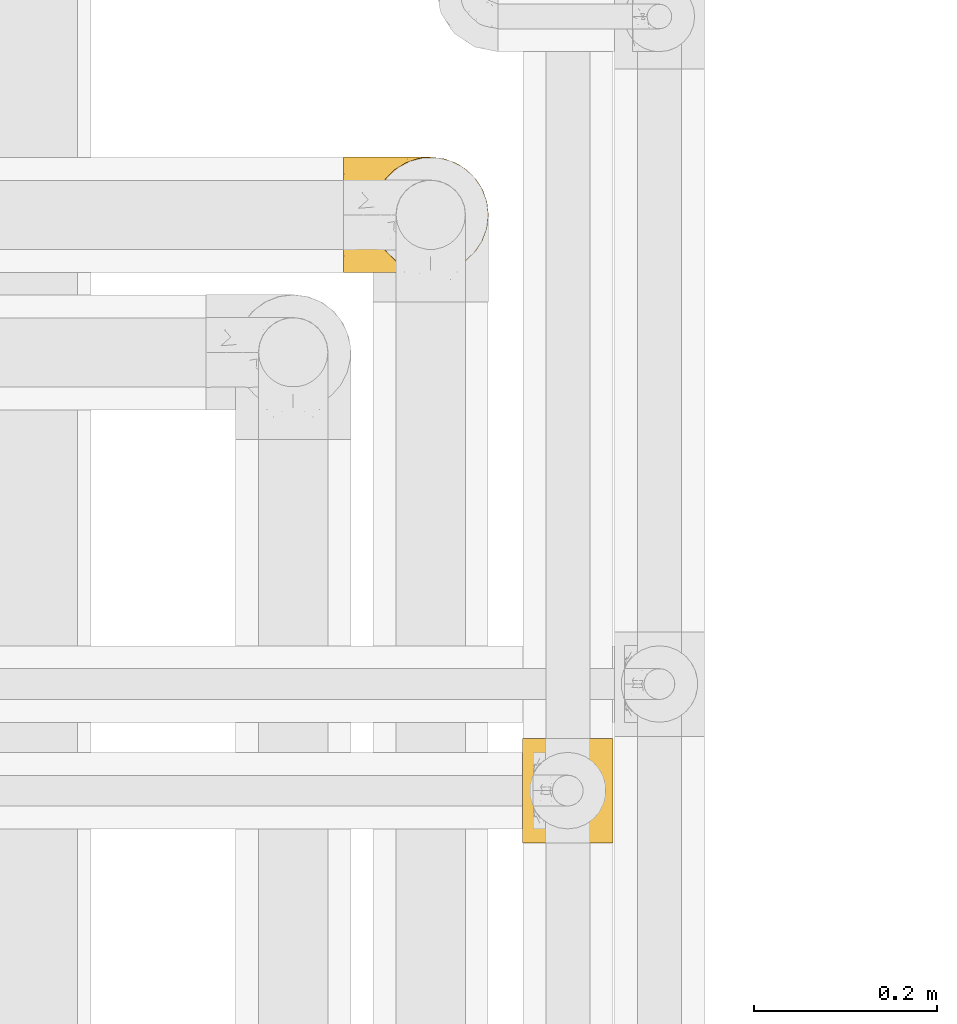
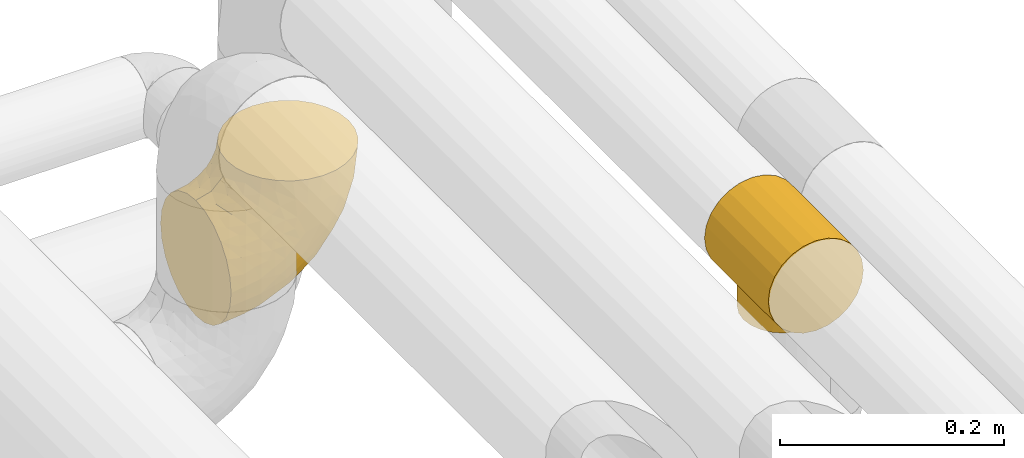
# One storey, part 491 of 827: 2 coverings.
"""IFC2X3 building model written with IfcOpenShell, lengths in millimetres."""

from ifc_helpers import new_model, entity, si_unit, converted_unit, derived_unit, direction, frame, origin, place, context, subcontext, project, spatial, faceted_brep, element, save


model = new_model("IFC2X3")

# Units and contexts
model_context = context("Model", 3, precision=0.01, world=origin(), true_north=direction((6.12303176911189e-17, 1.0)))
body_context = subcontext(model_context, "Body", "Model", "MODEL_VIEW")
ifc_project = project(units=[si_unit("LENGTHUNIT", "METRE", prefix="MILLI"), si_unit("AREAUNIT", "SQUARE_METRE"), si_unit("VOLUMEUNIT", "CUBIC_METRE"), converted_unit("PLANEANGLEUNIT", "DEGREE", entity("IfcRatioMeasure", 0.0174532925199433), si_unit("PLANEANGLEUNIT", "RADIAN"), dimensions=[0, 0, 0, 0, 0, 0, 0]), si_unit("MASSUNIT", "GRAM", prefix="KILO"), derived_unit("MASSDENSITYUNIT", [(si_unit("MASSUNIT", "GRAM", prefix="KILO"), 1), (si_unit("LENGTHUNIT", "METRE"), -3)]), derived_unit("MOMENTOFINERTIAUNIT", [(si_unit("LENGTHUNIT", "METRE"), 4)]), si_unit("TIMEUNIT", "SECOND"), si_unit("FREQUENCYUNIT", "HERTZ"), si_unit("THERMODYNAMICTEMPERATUREUNIT", "DEGREE_CELSIUS"), derived_unit("THERMALTRANSMITTANCEUNIT", [(si_unit("MASSUNIT", "GRAM", prefix="KILO"), 1), (si_unit("THERMODYNAMICTEMPERATUREUNIT", "KELVIN"), -1), (si_unit("TIMEUNIT", "SECOND"), -3)]), derived_unit("VOLUMETRICFLOWRATEUNIT", [(si_unit("LENGTHUNIT", "METRE"), 3), (si_unit("TIMEUNIT", "SECOND"), -1)]), derived_unit("MASSFLOWRATEUNIT", [(si_unit("MASSUNIT", "GRAM", prefix="KILO"), 1), (si_unit("TIMEUNIT", "SECOND"), -1)]), derived_unit("ROTATIONALFREQUENCYUNIT", [(si_unit("TIMEUNIT", "SECOND"), -1)]), si_unit("ELECTRICCURRENTUNIT", "AMPERE"), si_unit("ELECTRICVOLTAGEUNIT", "VOLT"), si_unit("POWERUNIT", "WATT"), si_unit("FORCEUNIT", "NEWTON", prefix="KILO"), si_unit("ILLUMINANCEUNIT", "LUX"), si_unit("LUMINOUSFLUXUNIT", "LUMEN"), si_unit("LUMINOUSINTENSITYUNIT", "CANDELA"), derived_unit("USERDEFINED", [(si_unit("MASSUNIT", "GRAM", prefix="KILO"), -1), (si_unit("LENGTHUNIT", "METRE"), -2), (si_unit("TIMEUNIT", "SECOND"), 3), (si_unit("LUMINOUSFLUXUNIT", "LUMEN"), 1)]), derived_unit("LINEARVELOCITYUNIT", [(si_unit("LENGTHUNIT", "METRE"), 1), (si_unit("TIMEUNIT", "SECOND"), -1)]), si_unit("PRESSUREUNIT", "PASCAL"), derived_unit("USERDEFINED", [(si_unit("LENGTHUNIT", "METRE"), -2), (si_unit("MASSUNIT", "GRAM", prefix="KILO"), 1), (si_unit("TIMEUNIT", "SECOND"), -2)]), derived_unit("LINEARFORCEUNIT", [(si_unit("MASSUNIT", "GRAM", prefix="KILO"), 1), (si_unit("LENGTHUNIT", "METRE"), 1), (si_unit("TIMEUNIT", "SECOND"), -2), (si_unit("LENGTHUNIT", "METRE"), -1)]), derived_unit("PLANARFORCEUNIT", [(si_unit("MASSUNIT", "GRAM", prefix="KILO"), 1), (si_unit("LENGTHUNIT", "METRE"), 1), (si_unit("TIMEUNIT", "SECOND"), -2), (si_unit("LENGTHUNIT", "METRE"), -2)])], contexts=[model_context])

# Site, building, storey
site_placement = place(None, origin())
site = spatial("IfcSite", under=ifc_project, at=site_placement, CompositionType="ELEMENT")
building_placement = place(site_placement, origin())
building = spatial("IfcBuilding", under=site, at=building_placement, CompositionType="ELEMENT")
storey_placement = place(building_placement, frame((0.0, 0.0, 28200.0)))
storey = spatial("IfcBuildingStorey", under=building, at=storey_placement, Name="08", CompositionType="ELEMENT", Elevation=28200.0)

# Coverings
covering_1_placement = place(storey_placement, frame((60806.51, 16007.73, 2635.39)))
element("IfcCovering", 1, at=covering_1_placement, inside=storey, Name=":ADSK_", ObjectType=":ADSK_", PredefinedType="INSULATION", context=body_context, shape_type="Brep", body=[
    faceted_brep([(110.62, 3.18, 159.65), (123.95, 7.84, 159.65), (135.9, 15.35, 159.65), (145.89, 25.33, 159.65), (153.4, 37.29, 159.65), (158.06, 50.61, 159.65), (159.65, 64.65, 159.65), (158.06, 78.67, 159.65), (153.4, 92.0, 159.65), (145.89, 103.95, 159.65), (135.91, 113.94, 159.65), (123.95, 121.45, 159.65), (110.63, 126.11, 159.65), (96.6, 127.7, 159.65), (82.57, 126.11, 159.65), (69.24, 121.45, 159.65), (57.29, 113.94, 159.65), (47.3, 103.96, 159.65), (39.79, 92.0, 159.65), (35.13, 78.68, 159.65), (33.55, 64.65, 159.65), (35.13, 50.62, 159.65), (39.79, 37.29, 159.65), (47.3, 25.34, 159.65), (57.28, 15.35, 159.65), (69.24, 7.84, 159.65), (82.56, 3.18, 159.65), (96.6, 1.6, 159.65), (1.6, 64.65, 127.7), (1.6, 80.96, 125.55), (1.6, 96.17, 119.25), (1.6, 109.23, 109.23), (1.6, 119.25, 96.17), (1.6, 125.55, 80.96), (1.6, 126.29, 75.35), (1.6, 127.7, 64.65), (1.6, 125.55, 48.33), (1.6, 119.25, 33.12), (1.6, 109.23, 20.06), (1.6, 96.17, 10.04), (1.6, 80.96, 3.74), (1.6, 64.65, 1.6), (1.6, 48.33, 3.74), (1.6, 33.12, 10.04), (1.6, 20.06, 20.06), (1.6, 10.04, 33.12), (1.6, 3.74, 48.33), (1.6, 1.6, 64.65), (1.6, 3.01, 75.35), (1.6, 3.74, 80.96), (1.6, 10.04, 96.17), (1.6, 20.06, 109.23), (1.6, 33.12, 119.25), (1.6, 48.33, 125.55), (30.13, 28.19, 16.01), (39.4, 42.57, 10.29), (62.65, 30.59, 24.76), (28.52, 53.36, 4.94), (42.5, 64.65, 6.98), (115.57, 15.9, 87.32), (98.94, 18.23, 62.3), (111.29, 32.42, 58.52), (95.5, 45.22, 36.35), (80.62, 64.65, 22.77), (113.35, 64.65, 47.89), (43.71, 9.73, 40.91), (70.76, 16.54, 42.82), (62.71, 6.44, 57.25), (33.16, 4.21, 51.19), (53.41, 2.65, 66.64), (130.65, 23.51, 98.56), (137.68, 35.48, 94.44), (146.84, 33.22, 123.53), (66.58, 42.18, 20.12), (57.7, 53.52, 12.95), (39.88, 17.3, 28.48), (154.26, 64.65, 118.74), (152.07, 45.71, 121.88), (125.54, 48.33, 65.08), (142.81, 50.95, 92.08), (103.99, 6.44, 98.53), (79.4, 3.41, 81.84), (88.81, 8.33, 72.43), (104.86, 2.62, 134.31), (117.38, 6.65, 129.11), (57.43, 1.6, 82.79), (44.19, 1.6, 76.04), (30.95, 1.6, 69.29), (139.96, 22.17, 129.58), (127.03, 14.22, 115.86), (87.17, 26.48, 42.36), (78.45, 1.6, 103.81), (73.2, 1.6, 98.55), (67.94, 1.6, 93.3), (94.63, 1.6, 147.25), (93.29, 1.6, 138.77), (91.95, 1.6, 130.29), (94.6, 2.65, 107.83), (85.2, 1.6, 117.05), (138.47, 64.65, 80.62), (13.99, 1.6, 66.61), (40.46, 16.24, 121.29), (32.36, 27.48, 128.09), (28.71, 20.83, 118.04), (15.53, 3.08, 79.47), (29.06, 6.64, 94.94), (40.03, 2.74, 86.01), (45.36, 3.84, 94.69), (26.46, 3.28, 83.06), (47.56, 5.99, 104.39), (36.28, 10.3, 107.01), (55.57, 15.78, 148.3), (45.02, 24.69, 143.82), (57.55, 11.25, 134.19), (11.56, 27.69, 116.87), (19.2, 19.31, 111.58), (10.07, 37.19, 122.36), (21.04, 33.01, 124.16), (15.52, 8.24, 94.28), (13.84, 49.89, 128.25), (32.67, 50.1, 146.72), (24.86, 48.9, 134.92), (34.31, 36.15, 138.87), (81.47, 2.54, 133.28), (71.26, 3.58, 121.77), (81.64, 3.12, 145.83), (29.26, 64.65, 143.67), (70.65, 6.01, 139.93), (31.93, 64.65, 153.63), (27.99, 37.71, 132.32), (41.71, 22.19, 132.59), (50.14, 13.01, 126.42), (17.57, 12.97, 102.97), (37.62, 38.95, 149.52), (60.48, 6.55, 120.88), (17.57, 64.65, 131.98), (56.96, 2.52, 96.12), (48.98, 9.45, 115.84), (57.29, 4.58, 108.2), (68.25, 2.83, 110.85), (10.07, 92.1, 122.36), (16.58, 101.63, 118.35), (13.84, 79.39, 128.25), (13.99, 127.7, 66.61), (32.67, 79.2, 146.72), (24.86, 80.4, 134.92), (67.81, 126.41, 110.73), (61.09, 122.74, 121.83), (71.26, 125.71, 121.77), (57.43, 127.7, 82.79), (44.19, 127.7, 76.04), (40.03, 126.55, 86.01), (57.55, 118.04, 134.19), (51.01, 117.36, 124.9), (42.79, 108.2, 132.35), (26.46, 126.01, 83.06), (29.06, 122.65, 94.94), (17.57, 116.32, 102.97), (19.2, 109.98, 111.58), (40.46, 113.06, 121.29), (28.84, 107.85, 118.82), (33.48, 102.33, 128.68), (15.52, 121.05, 94.28), (15.53, 126.21, 79.47), (36.28, 118.99, 107.01), (37.62, 90.34, 149.51), (21.04, 96.28, 124.16), (94.63, 127.7, 147.25), (93.29, 127.7, 138.77), (34.31, 93.14, 138.87), (45.03, 104.6, 143.82), (70.65, 123.28, 139.92), (81.47, 126.75, 133.28), (55.58, 113.51, 148.3), (91.95, 127.7, 130.29), (81.64, 126.17, 145.83), (27.86, 91.96, 131.94), (78.45, 127.7, 103.81), (85.2, 127.7, 117.05), (56.96, 126.77, 96.12), (45.36, 125.45, 94.69), (47.57, 123.3, 104.39), (48.27, 119.94, 114.83), (67.94, 127.7, 93.3), (57.3, 124.71, 108.2), (30.95, 127.7, 69.29), (62.65, 98.7, 24.76), (30.13, 101.1, 16.01), (39.88, 111.99, 28.48), (43.71, 119.56, 40.91), (39.4, 86.72, 10.29), (55.79, 75.78, 12.23), (28.41, 75.87, 4.91), (53.41, 126.64, 66.64), (104.86, 126.67, 134.31), (117.39, 122.63, 129.11), (103.99, 122.85, 98.53), (125.54, 80.96, 65.08), (111.29, 96.87, 58.52), (137.69, 93.81, 94.45), (94.6, 126.64, 107.83), (79.4, 125.88, 81.84), (33.16, 125.08, 51.19), (68.78, 86.22, 20.8), (130.66, 105.77, 98.56), (139.97, 107.12, 129.58), (148.6, 96.19, 131.93), (115.58, 113.39, 87.32), (127.03, 115.06, 115.86), (70.76, 112.75, 42.82), (95.5, 84.07, 36.35), (62.71, 122.85, 57.25), (88.81, 120.97, 72.43), (98.94, 111.06, 62.3), (89.09, 96.3, 38.39), (78.72, 75.94, 22.86), (142.21, 80.53, 92.06), (152.07, 83.57, 121.88)], [[[0, 1, 2, 3, 4, 5, 6, 7, 8, 9, 10, 11, 12, 13, 14, 15, 16, 17, 18, 19, 20, 21, 22, 23, 24, 25, 26, 27]], [[28, 29, 30, 31, 32, 33, 34, 35, 36, 37, 38, 39, 40, 41, 42, 43, 44, 45, 46, 47, 48, 49, 50, 51, 52, 53]], [[54, 55, 56]], [[57, 41, 58]], [[59, 60, 61]], [[62, 63, 64]], [[65, 66, 67]], [[68, 67, 69]], [[70, 71, 72]], [[55, 73, 56]], [[43, 42, 55]], [[55, 74, 73]], [[44, 75, 45]], [[44, 43, 54]], [[76, 5, 77]], [[71, 78, 79]], [[45, 75, 65]], [[46, 68, 47]], [[80, 81, 82]], [[0, 83, 84]], [[69, 85, 86, 87]], [[69, 81, 85]], [[84, 1, 0]], [[2, 88, 3]], [[4, 3, 72]], [[44, 54, 75]], [[5, 4, 77]], [[89, 2, 1]], [[72, 3, 88]], [[5, 76, 6]], [[70, 88, 89]], [[68, 65, 67]], [[88, 2, 89]], [[56, 90, 66]], [[64, 78, 62]], [[81, 91, 92, 93, 85]], [[83, 27, 94, 95, 96]], [[62, 61, 90]], [[97, 96, 98, 91]], [[80, 97, 81]], [[42, 57, 55]], [[62, 78, 61]], [[84, 89, 1]], [[78, 64, 99]], [[57, 74, 55]], [[76, 77, 79]], [[77, 72, 71]], [[82, 81, 67]], [[97, 83, 96]], [[80, 89, 84]], [[79, 78, 99]], [[71, 70, 61]], [[81, 97, 91]], [[83, 80, 84]], [[68, 87, 100, 47]], [[81, 69, 67]], [[68, 69, 87]], [[65, 46, 45]], [[65, 68, 46]], [[66, 65, 75]], [[56, 66, 75]], [[66, 60, 82]], [[71, 61, 78]], [[60, 66, 90]], [[83, 97, 80]], [[27, 83, 0]], [[59, 70, 89]], [[70, 59, 61]], [[89, 80, 59]], [[82, 59, 80]], [[55, 54, 43]], [[75, 54, 56]], [[66, 82, 67]], [[59, 82, 60]], [[41, 57, 42]], [[74, 57, 58]], [[58, 63, 74]], [[62, 74, 63]], [[74, 62, 73]], [[62, 56, 73]], [[4, 72, 77]], [[70, 72, 88]], [[76, 79, 99]], [[71, 79, 77]], [[62, 90, 56]], [[60, 90, 61]], [[101, 102, 103]], [[100, 87, 104]], [[105, 106, 107]], [[108, 104, 87]], [[107, 109, 110]], [[108, 87, 86]], [[111, 112, 113]], [[114, 51, 115]], [[116, 114, 117]], [[51, 50, 118]], [[119, 28, 53]], [[120, 121, 122]], [[98, 123, 124]], [[125, 96, 95]], [[116, 53, 52]], [[126, 121, 120]], [[104, 108, 118]], [[98, 124, 91]], [[25, 24, 127]], [[120, 128, 126]], [[122, 129, 102]], [[95, 94, 27, 26]], [[122, 102, 130]], [[125, 127, 123]], [[24, 111, 127]], [[21, 20, 128]], [[112, 130, 131]], [[48, 47, 100, 49]], [[132, 110, 115]], [[23, 111, 24]], [[129, 119, 117]], [[120, 133, 21]], [[112, 23, 22]], [[134, 113, 131]], [[121, 126, 135]], [[133, 112, 22]], [[128, 120, 21]], [[132, 51, 118]], [[120, 122, 133]], [[119, 121, 135]], [[129, 117, 102]], [[125, 26, 25]], [[26, 125, 95]], [[127, 125, 25]], [[28, 119, 135]], [[119, 53, 116]], [[127, 113, 124]], [[96, 125, 123]], [[112, 131, 113]], [[101, 103, 110]], [[85, 93, 136]], [[124, 123, 127]], [[98, 96, 123]], [[112, 111, 23]], [[127, 111, 113]], [[112, 133, 122]], [[21, 133, 22]], [[107, 110, 105]], [[110, 109, 137]], [[86, 106, 108]], [[138, 109, 136]], [[105, 118, 108]], [[107, 106, 85]], [[104, 50, 49]], [[124, 134, 139]], [[138, 93, 92]], [[92, 91, 139]], [[100, 104, 49]], [[118, 105, 132]], [[104, 118, 50]], [[110, 132, 105]], [[51, 132, 115]], [[108, 106, 105]], [[85, 106, 86]], [[114, 116, 52]], [[119, 116, 117]], [[51, 114, 52]], [[114, 115, 103]], [[117, 114, 103]], [[130, 102, 101]], [[117, 103, 102]], [[110, 103, 115]], [[130, 101, 131]], [[122, 130, 112]], [[101, 137, 131]], [[113, 134, 124]], [[137, 134, 131]], [[124, 139, 91]], [[134, 138, 139]], [[92, 139, 138]], [[110, 137, 101]], [[134, 137, 138]], [[136, 109, 107]], [[137, 109, 138]], [[85, 136, 107]], [[138, 136, 93]], [[122, 121, 129]], [[129, 121, 119]], [[30, 140, 141]], [[30, 29, 140]], [[28, 135, 142]], [[143, 35, 34, 33]], [[19, 144, 128]], [[126, 145, 135]], [[146, 147, 148]], [[149, 150, 151]], [[152, 153, 154]], [[155, 156, 151]], [[157, 31, 158]], [[159, 160, 161]], [[32, 162, 163]], [[158, 31, 30]], [[157, 164, 156]], [[126, 144, 145]], [[126, 128, 144]], [[18, 165, 19]], [[141, 166, 160]], [[14, 13, 167, 168]], [[163, 143, 33]], [[169, 165, 170]], [[18, 17, 170]], [[153, 159, 154]], [[142, 135, 145]], [[148, 171, 172]], [[159, 161, 154]], [[171, 152, 173]], [[173, 17, 16]], [[16, 15, 171]], [[158, 160, 164]], [[174, 175, 168]], [[173, 170, 17]], [[19, 128, 20]], [[174, 172, 175]], [[165, 169, 144]], [[162, 157, 156]], [[175, 172, 171]], [[144, 169, 145]], [[176, 169, 161]], [[166, 140, 142]], [[175, 171, 15]], [[168, 175, 14]], [[14, 175, 15]], [[142, 145, 176]], [[28, 142, 29]], [[148, 177, 146]], [[148, 178, 177]], [[152, 171, 148]], [[179, 180, 181]], [[164, 180, 156]], [[174, 178, 172]], [[148, 172, 178]], [[171, 173, 16]], [[170, 173, 152]], [[19, 165, 144]], [[170, 165, 18]], [[153, 182, 159]], [[146, 183, 184]], [[181, 180, 164]], [[180, 151, 156]], [[163, 155, 185]], [[155, 150, 185]], [[162, 156, 155]], [[143, 163, 185]], [[180, 179, 149]], [[32, 163, 33]], [[163, 162, 155]], [[31, 162, 32]], [[31, 157, 162]], [[164, 157, 158]], [[149, 151, 180]], [[155, 151, 150]], [[142, 140, 29]], [[141, 140, 166]], [[176, 145, 169]], [[30, 141, 158]], [[164, 160, 159]], [[158, 141, 160]], [[166, 161, 160]], [[154, 169, 170]], [[169, 154, 161]], [[152, 154, 170]], [[147, 152, 148]], [[153, 147, 182]], [[181, 182, 184]], [[164, 159, 182]], [[161, 166, 176]], [[142, 176, 166]], [[183, 146, 177]], [[184, 182, 147]], [[184, 147, 146]], [[152, 147, 153]], [[182, 181, 164]], [[179, 184, 183]], [[184, 179, 181]], [[149, 179, 183]], [[186, 187, 188]], [[37, 36, 189]], [[190, 191, 192]], [[193, 185, 150, 149]], [[194, 195, 196]], [[197, 198, 199]], [[200, 201, 177]], [[193, 202, 185]], [[203, 190, 186]], [[202, 189, 36]], [[41, 40, 192]], [[204, 205, 199]], [[9, 8, 206]], [[187, 190, 39]], [[40, 39, 190]], [[38, 37, 188]], [[207, 208, 204]], [[202, 35, 143, 185]], [[39, 38, 187]], [[195, 11, 208]], [[201, 149, 183, 177]], [[188, 189, 209]], [[197, 64, 210]], [[186, 188, 209]], [[13, 12, 194]], [[211, 201, 212]], [[12, 11, 195]], [[193, 201, 211]], [[212, 201, 196]], [[10, 208, 11]], [[213, 214, 209]], [[64, 63, 215]], [[216, 197, 199]], [[8, 217, 206]], [[7, 217, 8]], [[203, 191, 190]], [[7, 6, 76]], [[208, 205, 204]], [[205, 10, 9]], [[199, 205, 206]], [[7, 76, 217]], [[205, 208, 10]], [[216, 76, 99]], [[200, 177, 178, 174]], [[64, 197, 99]], [[63, 58, 191]], [[208, 196, 195]], [[196, 200, 194]], [[198, 197, 210]], [[216, 199, 217]], [[201, 193, 149]], [[202, 193, 211]], [[202, 211, 189]], [[35, 202, 36]], [[211, 212, 209]], [[37, 189, 188]], [[211, 209, 189]], [[213, 198, 214]], [[200, 174, 194]], [[201, 200, 196]], [[214, 198, 210]], [[213, 207, 198]], [[194, 174, 168, 167, 13]], [[195, 194, 12]], [[198, 204, 199]], [[204, 198, 207]], [[212, 207, 213]], [[196, 208, 207]], [[188, 187, 38]], [[190, 187, 186]], [[207, 212, 196]], [[209, 212, 213]], [[214, 203, 186]], [[191, 215, 63]], [[191, 203, 215]], [[192, 191, 58]], [[41, 192, 58]], [[190, 192, 40]], [[203, 210, 215]], [[64, 215, 210]], [[199, 206, 217]], [[9, 206, 205]], [[76, 216, 217]], [[99, 197, 216]], [[203, 214, 210]], [[209, 214, 186]]]),
])
covering_2_placement = place(storey_placement, frame((61001.89, 15387.21, 2942.74)))
element("IfcCovering", 2, at=covering_2_placement, inside=storey, Name=":ADSK_", ObjectType=":ADSK_", PredefinedType="INSULATION", context=body_context, shape_type="Brep", body=[
    faceted_brep([(26.17, 114.0, 99.57), (38.02, 114.0, 104.48), (50.75, 114.0, 106.15), (63.47, 114.0, 104.48), (75.32, 114.0, 99.57), (85.5, 114.0, 91.75), (93.31, 114.0, 81.58), (98.22, 114.0, 69.72), (99.9, 114.0, 57.0), (98.22, 114.0, 44.28), (93.31, 114.0, 32.43), (89.4, 114.0, 27.34), (85.5, 114.0, 22.25), (80.41, 114.0, 18.34), (75.32, 114.0, 14.43), (69.39, 114.0, 11.98), (66.43, 114.0, 10.75), (63.47, 114.0, 9.52), (60.29, 114.0, 9.11), (57.11, 114.0, 8.69), (53.93, 114.0, 8.27), (50.75, 114.0, 7.85), (47.57, 114.0, 8.27), (44.38, 114.0, 8.69), (41.2, 114.0, 9.11), (38.02, 114.0, 9.52), (35.06, 114.0, 10.75), (32.1, 114.0, 11.98), (26.17, 114.0, 14.43), (21.08, 114.0, 18.34), (15.99, 114.0, 22.25), (12.09, 114.0, 27.34), (8.18, 114.0, 32.43), (3.27, 114.0, 44.28), (1.6, 114.0, 57.0), (3.27, 114.0, 69.72), (8.18, 114.0, 81.58), (15.99, 114.0, 91.75), (98.22, 0.0, 69.72), (93.31, 0.0, 81.58), (85.5, 0.0, 91.75), (75.32, 0.0, 99.57), (63.47, 0.0, 104.48), (50.75, 0.0, 106.15), (38.02, 0.0, 104.48), (26.17, 0.0, 99.57), (15.99, 0.0, 91.75), (8.18, 0.0, 81.58), (3.27, 0.0, 69.72), (1.6, 0.0, 57.0), (3.27, 0.0, 44.28), (8.18, 0.0, 32.43), (12.09, 0.0, 27.34), (15.99, 0.0, 22.25), (21.08, 0.0, 18.34), (26.17, 0.0, 14.43), (32.1, 0.0, 11.98), (35.06, 0.0, 10.75), (38.02, 0.0, 9.52), (41.2, 0.0, 9.11), (44.38, 0.0, 8.69), (47.57, 0.0, 8.27), (50.75, 0.0, 7.85), (53.93, 0.0, 8.27), (57.11, 0.0, 8.69), (60.29, 0.0, 9.11), (63.47, 0.0, 9.52), (66.43, 0.0, 10.75), (69.39, 0.0, 11.98), (75.32, 0.0, 14.43), (80.41, 0.0, 18.34), (85.5, 0.0, 22.25), (89.4, 0.0, 27.34), (93.31, 0.0, 32.43), (98.22, 0.0, 44.28), (99.9, 0.0, 57.0), (92.6, 57.0, 31.23), (83.63, 31.11, 20.47), (88.32, 38.57, 25.32), (69.73, 94.29, 11.67), (65.2, 95.97, 10.26), (91.44, 47.21, 29.43), (88.32, 75.43, 25.32), (53.23, 15.45, 8.1), (50.75, 15.15, 7.85), (53.23, 98.55, 8.1), (50.75, 98.85, 7.85), (60.68, 97.65, 8.86), (55.71, 98.25, 8.36), (91.44, 66.79, 29.43), (83.63, 82.89, 20.47), (77.43, 89.24, 15.72), (77.43, 24.76, 15.72), (73.58, 22.23, 13.69), (65.2, 18.03, 10.26), (60.68, 16.35, 8.86), (55.71, 15.75, 8.36), (69.73, 19.71, 11.67), (73.58, 91.77, 13.69), (45.78, 15.75, 8.36), (40.81, 16.35, 8.86), (40.81, 97.65, 8.86), (27.91, 22.23, 13.69), (24.06, 24.76, 15.72), (31.76, 19.71, 11.67), (17.86, 31.11, 20.47), (36.29, 18.03, 10.26), (48.26, 15.45, 8.1), (45.78, 98.25, 8.36), (13.17, 38.57, 25.32), (48.26, 98.55, 8.1), (27.91, 91.77, 13.69), (24.06, 89.24, 15.72), (36.29, 95.97, 10.26), (31.76, 94.29, 11.67), (10.06, 47.21, 29.43), (8.9, 57.0, 31.23), (13.17, 75.43, 25.32), (17.86, 82.89, 20.47), (10.06, 66.79, 29.43), (91.17, 46.17, 0.0), (86.99, 36.07, 0.0), (80.34, 27.41, 0.0), (71.67, 20.76, 0.0), (61.58, 16.58, 0.0), (50.75, 15.15, 0.0), (39.91, 16.58, 0.0), (29.82, 20.76, 0.0), (21.15, 27.41, 0.0), (14.5, 36.07, 0.0), (10.32, 46.17, 0.0), (8.9, 57.0, 0.0), (10.32, 67.83, 0.0), (14.5, 77.92, 0.0), (21.15, 86.59, 0.0), (29.82, 93.24, 0.0), (39.91, 97.42, 0.0), (50.75, 98.85, 0.0), (61.58, 97.42, 0.0), (71.67, 93.24, 0.0), (80.34, 86.59, 0.0), (86.99, 77.92, 0.0), (91.17, 67.83, 0.0), (92.6, 57.0, 0.0)], [[[0, 1, 2, 3, 4, 5, 6, 7, 8, 9, 10, 11, 12, 13, 14, 15, 16, 17, 18, 19, 20, 21, 22, 23, 24, 25, 26, 27, 28, 29, 30, 31, 32, 33, 34, 35, 36, 37]], [[38, 39, 40, 41, 42, 43, 44, 45, 46, 47, 48, 49, 50, 51, 52, 53, 54, 55, 56, 57, 58, 59, 60, 61, 62, 63, 64, 65, 66, 67, 68, 69, 70, 71, 72, 73, 74, 75]], [[41, 40, 5, 4]], [[2, 43, 42, 3]], [[42, 41, 4, 3]], [[6, 39, 38, 7]], [[7, 38, 75, 8]], [[5, 40, 39, 6]], [[74, 9, 8, 75]], [[73, 76, 74]], [[71, 77, 78]], [[71, 70, 77]], [[16, 79, 80]], [[73, 72, 81]], [[82, 12, 11]], [[78, 72, 71]], [[81, 76, 73]], [[9, 76, 10]], [[83, 62, 84]], [[21, 85, 86]], [[19, 87, 88]], [[11, 89, 82]], [[85, 21, 20]], [[10, 89, 11]], [[90, 12, 82]], [[91, 14, 13]], [[89, 10, 76]], [[74, 76, 9]], [[81, 72, 78]], [[80, 17, 16]], [[92, 69, 93]], [[77, 70, 92]], [[67, 66, 94]], [[95, 66, 65, 64]], [[96, 63, 83]], [[68, 93, 69]], [[95, 64, 96]], [[97, 68, 67]], [[79, 16, 15]], [[13, 12, 90]], [[93, 68, 97]], [[98, 15, 14]], [[15, 98, 79]], [[66, 95, 94]], [[13, 90, 91]], [[20, 19, 88]], [[14, 91, 98]], [[20, 88, 85]], [[18, 17, 87, 19]], [[97, 67, 94]], [[87, 17, 80]], [[62, 83, 63]], [[92, 70, 69]], [[96, 64, 63]], [[60, 99, 61]], [[100, 60, 59, 58]], [[101, 25, 24, 23]], [[55, 102, 56]], [[103, 55, 54]], [[104, 56, 102]], [[53, 105, 54]], [[58, 106, 100]], [[107, 62, 61]], [[101, 23, 108]], [[109, 53, 52]], [[22, 110, 108]], [[106, 58, 57]], [[111, 112, 28]], [[57, 104, 106]], [[110, 21, 86]], [[62, 107, 84]], [[25, 113, 26]], [[112, 29, 28]], [[26, 114, 27]], [[104, 57, 56]], [[60, 100, 99]], [[55, 103, 102]], [[105, 53, 109]], [[105, 103, 54]], [[52, 51, 115]], [[25, 101, 113]], [[116, 51, 50]], [[116, 115, 51]], [[115, 109, 52]], [[50, 49, 34, 33]], [[111, 27, 114]], [[30, 117, 31]], [[118, 29, 112]], [[30, 29, 118]], [[30, 118, 117]], [[119, 32, 31]], [[116, 32, 119]], [[32, 116, 33]], [[21, 110, 22]], [[33, 116, 50]], [[108, 23, 22]], [[119, 31, 117]], [[61, 99, 107]], [[27, 111, 28]], [[114, 26, 113]], [[35, 48, 47, 36]], [[36, 47, 46, 37]], [[49, 48, 35, 34]], [[0, 45, 44, 1]], [[1, 44, 43, 2]], [[37, 46, 45, 0]], [[120, 121, 122, 123, 124, 125, 126, 127, 128, 129, 130, 131, 132, 133, 134, 135, 136, 137, 138, 139, 140, 141, 142, 143]], [[95, 125, 124]], [[97, 124, 123]], [[125, 95, 96, 83, 84]], [[123, 92, 93, 97]], [[124, 97, 94, 95]], [[123, 122, 92]], [[122, 121, 77]], [[121, 120, 78]], [[81, 120, 143]], [[77, 121, 78]], [[81, 78, 120]], [[76, 81, 143]], [[122, 77, 92]], [[89, 143, 142]], [[82, 142, 141]], [[76, 143, 89]], [[89, 142, 82]], [[141, 90, 82]], [[141, 140, 90]], [[91, 140, 139]], [[138, 137, 87]], [[79, 139, 138]], [[139, 79, 98, 91]], [[137, 86, 85, 88, 87]], [[138, 87, 80, 79]], [[140, 91, 90]], [[101, 137, 136]], [[114, 136, 135]], [[137, 101, 108, 110, 86]], [[135, 112, 111, 114]], [[136, 114, 113, 101]], [[135, 134, 112]], [[118, 134, 133]], [[133, 132, 117]], [[131, 119, 132]], [[118, 133, 117]], [[119, 117, 132]], [[116, 119, 131]], [[134, 118, 112]], [[115, 131, 130]], [[109, 130, 129]], [[116, 131, 115]], [[115, 130, 109]], [[129, 105, 109]], [[129, 128, 105]], [[103, 128, 127]], [[127, 126, 104]], [[125, 100, 126]], [[127, 104, 102, 103]], [[125, 84, 107, 99, 100]], [[126, 100, 106, 104]], [[128, 103, 105]]]),
])

save(model, "model.ifc")
